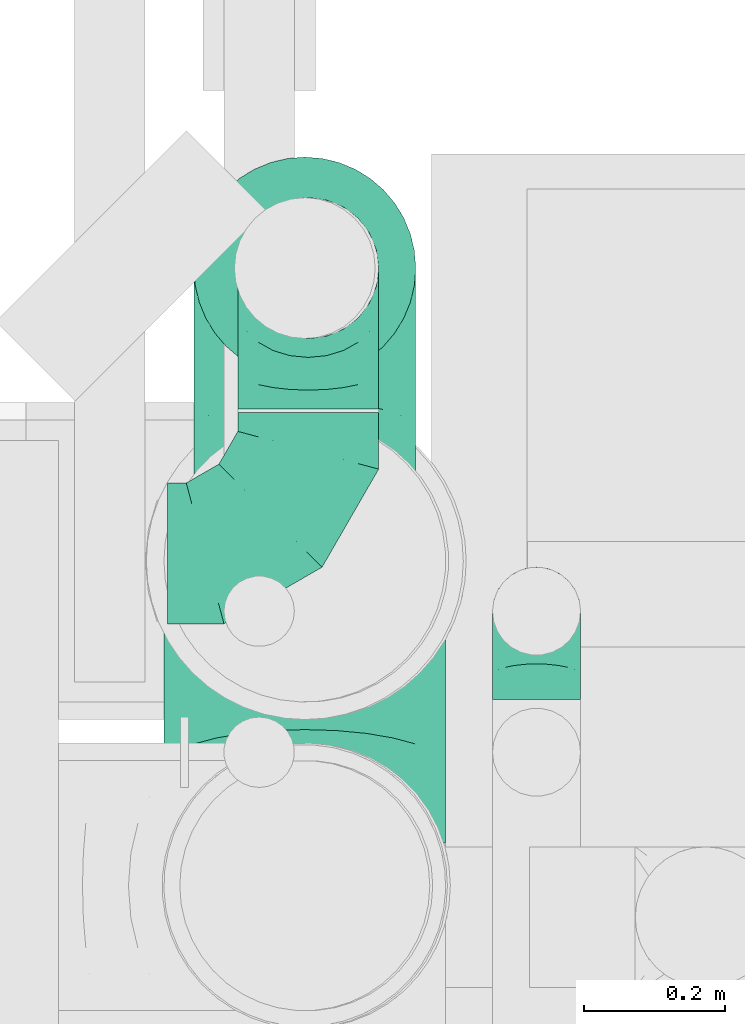
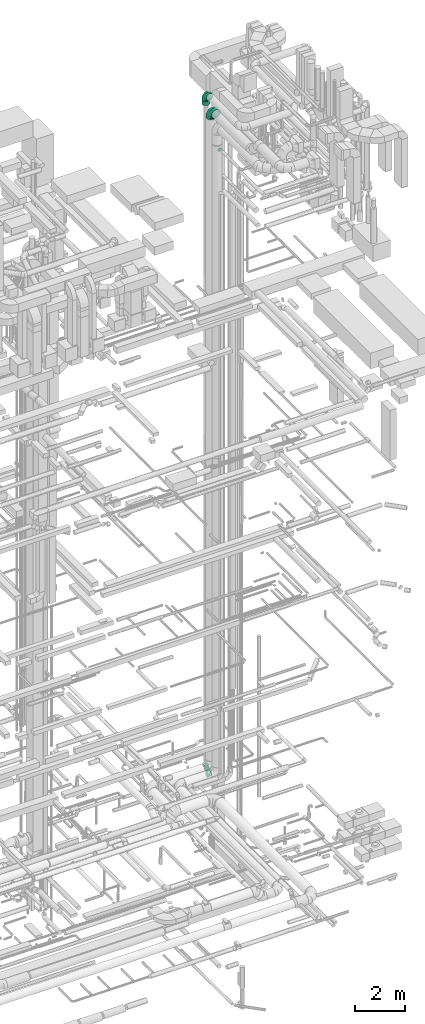
# One storey, part 270 of 337: 5 flow fittings, 1 flow segment.
"""IFC2X3 building model written with IfcOpenShell, lengths in millimetres."""

from ifc_helpers import new_model, entity, si_unit, converted_unit, derived_unit, direction, frame, origin, origin_2d_with_axis, place, context, subcontext, project, spatial, circle, extrude, faceted_brep, source, transform, mapped, material, type_object, type_shapes, element, save


model = new_model("IFC2X3")

# Units and contexts
model_context = context("Model", 3, precision=0.01, world=origin(), true_north=direction((6.12303176911189e-17, 1.0)))
body_context = subcontext(model_context, "Body", "Model", "MODEL_VIEW")
ifc_project = project(units=[si_unit("LENGTHUNIT", "METRE", prefix="MILLI"), si_unit("AREAUNIT", "SQUARE_METRE"), si_unit("VOLUMEUNIT", "CUBIC_METRE"), converted_unit("PLANEANGLEUNIT", "DEGREE", entity("IfcRatioMeasure", 0.0174532925199433), si_unit("PLANEANGLEUNIT", "RADIAN"), dimensions=[0, 0, 0, 0, 0, 0, 0]), si_unit("MASSUNIT", "GRAM", prefix="KILO"), derived_unit("MASSDENSITYUNIT", [(si_unit("MASSUNIT", "GRAM", prefix="KILO"), 1), (si_unit("LENGTHUNIT", "METRE"), -3)]), derived_unit("MOMENTOFINERTIAUNIT", [(si_unit("LENGTHUNIT", "METRE"), 4)]), si_unit("TIMEUNIT", "SECOND"), si_unit("FREQUENCYUNIT", "HERTZ"), si_unit("THERMODYNAMICTEMPERATUREUNIT", "DEGREE_CELSIUS"), derived_unit("THERMALTRANSMITTANCEUNIT", [(si_unit("MASSUNIT", "GRAM", prefix="KILO"), 1), (si_unit("THERMODYNAMICTEMPERATUREUNIT", "KELVIN"), -1), (si_unit("TIMEUNIT", "SECOND"), -3)]), derived_unit("VOLUMETRICFLOWRATEUNIT", [(si_unit("LENGTHUNIT", "METRE"), 3), (si_unit("TIMEUNIT", "SECOND"), -1)]), derived_unit("MASSFLOWRATEUNIT", [(si_unit("MASSUNIT", "GRAM", prefix="KILO"), 1), (si_unit("TIMEUNIT", "SECOND"), -1)]), derived_unit("ROTATIONALFREQUENCYUNIT", [(si_unit("TIMEUNIT", "SECOND"), -1)]), si_unit("ELECTRICCURRENTUNIT", "AMPERE"), si_unit("ELECTRICVOLTAGEUNIT", "VOLT"), si_unit("POWERUNIT", "WATT"), si_unit("FORCEUNIT", "NEWTON", prefix="KILO"), si_unit("ILLUMINANCEUNIT", "LUX"), si_unit("LUMINOUSFLUXUNIT", "LUMEN"), si_unit("LUMINOUSINTENSITYUNIT", "CANDELA"), derived_unit("USERDEFINED", [(si_unit("MASSUNIT", "GRAM", prefix="KILO"), -1), (si_unit("LENGTHUNIT", "METRE"), -2), (si_unit("TIMEUNIT", "SECOND"), 3), (si_unit("LUMINOUSFLUXUNIT", "LUMEN"), 1)]), derived_unit("LINEARVELOCITYUNIT", [(si_unit("LENGTHUNIT", "METRE"), 1), (si_unit("TIMEUNIT", "SECOND"), -1)]), si_unit("PRESSUREUNIT", "PASCAL"), derived_unit("USERDEFINED", [(si_unit("LENGTHUNIT", "METRE"), -2), (si_unit("MASSUNIT", "GRAM", prefix="KILO"), 1), (si_unit("TIMEUNIT", "SECOND"), -2)]), derived_unit("LINEARFORCEUNIT", [(si_unit("MASSUNIT", "GRAM", prefix="KILO"), 1), (si_unit("LENGTHUNIT", "METRE"), 1), (si_unit("TIMEUNIT", "SECOND"), -2), (si_unit("LENGTHUNIT", "METRE"), -1)]), derived_unit("PLANARFORCEUNIT", [(si_unit("MASSUNIT", "GRAM", prefix="KILO"), 1), (si_unit("LENGTHUNIT", "METRE"), 1), (si_unit("TIMEUNIT", "SECOND"), -2), (si_unit("LENGTHUNIT", "METRE"), -2)])], contexts=[model_context])

# Site, building, storey
site_placement = place(None, origin())
site = spatial("IfcSite", under=ifc_project, at=site_placement, CompositionType="ELEMENT")
building_placement = place(site_placement, origin())
building = spatial("IfcBuilding", under=site, at=building_placement, CompositionType="ELEMENT")
storey_placement = place(building_placement, origin())
storey = spatial("IfcBuildingStorey", under=building, at=storey_placement, CompositionType="ELEMENT", Elevation=0.0)

# Flow segment
duct_segment_type = type_object("IfcDuctSegmentType", PredefinedType="NOTDEFINED")
flow_segment_placement = place(storey_placement, frame((67399.96, 12506.71, 35005.21)))
element("IfcFlowSegment", 1, at=flow_segment_placement, inside=storey, type_object=duct_segment_type, context=body_context, shape_type="SweptSolid", body=[
    extrude(circle(Radius=157.5, at=origin_2d_with_axis()), frame((159.1, 159.1, 0.0), z_axis=(0.0, 0.0, 1.0), x_axis=(0.0, 1.0, 0.0)), (0.0, 0.0, 1.0), 199.793476749962),
])

# Flow fittings
ifc_material = material()
duct_fitting_type_1 = type_object("IfcDuctFittingType", PredefinedType="NOTDEFINED", material=ifc_material)
shared_shape_1 = source(origin(), body_context, "Body", "Brep", [
    faceted_brep([(-200.0, 0.0, -100.0), (-200.0, -25.88, -96.59), (-200.0, -50.0, -86.6), (-200.0, -70.71, -70.71), (-200.0, -86.6, -50.0), (-200.0, -96.59, -25.88), (-200.0, -100.0, 0.0), (-200.0, -96.59, 25.88), (-200.0, -86.6, 50.0), (-200.0, -70.71, 70.71), (-200.0, -50.0, 86.6), (-200.0, -25.88, 96.59), (-200.0, 0.0, 100.0), (-200.0, 25.88, 96.59), (-200.0, 50.0, 86.6), (-200.0, 70.71, 70.71), (-200.0, 86.6, 50.0), (-200.0, 96.59, 25.88), (-200.0, 100.0, 0.0), (-200.0, 96.59, -25.88), (-200.0, 86.6, -50.0), (-200.0, 70.71, -70.71), (-200.0, 50.0, -86.6), (-200.0, 25.88, -96.59), (-153.35, 25.88, 96.59), (-159.81, 50.0, 86.6), (-146.41, 0.0, 100.0), (-165.36, 70.71, 70.71), (-172.29, 96.59, 25.88), (-173.21, 100.0, 0.0), (-169.62, 86.6, 50.0), (-169.62, 86.6, -50.0), (-165.36, 70.71, -70.71), (-172.29, 96.59, -25.88), (-153.35, 25.88, -96.59), (-146.41, 0.0, -100.0), (-159.81, 50.0, -86.6), (-139.48, -25.88, -96.59), (-133.01, -50.0, -86.6), (-127.46, -70.71, -70.71), (-123.21, -86.6, -50.0), (-120.53, -96.59, -25.88), (-119.62, -100.0, 0.0), (-120.53, -96.59, 25.88), (-123.21, -86.6, 50.0), (-127.46, -70.71, 70.71), (-133.01, -50.0, 86.6), (-139.48, -25.88, 96.59), (-72.54, 72.54, 96.59), (-90.19, 90.19, 86.6), (-53.59, 53.59, 100.0), (-105.35, 105.35, 70.71), (-116.99, 116.99, 50.0), (-124.3, 124.3, 25.88), (-126.79, 126.79, 0.0), (-124.3, 124.3, -25.88), (-116.99, 116.99, -50.0), (-105.35, 105.35, -70.71), (-72.54, 72.54, -96.59), (-53.59, 53.59, -100.0), (-90.19, 90.19, -86.6), (-34.64, 34.64, -96.59), (-16.99, 16.99, -86.6), (-1.83, 1.83, -70.71), (9.81, -9.81, -50.0), (17.12, -17.12, -25.88), (19.62, -19.62, 0.0), (17.12, -17.12, 25.88), (9.81, -9.81, 50.0), (-1.83, 1.83, 70.71), (-16.99, 16.99, 86.6), (-34.64, 34.64, 96.59), (-25.88, 153.35, 96.59), (-50.0, 159.81, 86.6), (0.0, 146.41, 100.0), (-70.71, 165.36, 70.71), (-86.6, 169.62, 50.0), (-96.59, 172.29, 25.88), (-100.0, 173.21, 0.0), (-96.59, 172.29, -25.88), (-86.6, 169.62, -50.0), (-70.71, 165.36, -70.71), (-25.88, 153.35, -96.59), (0.0, 146.41, -100.0), (-50.0, 159.81, -86.6), (25.88, 139.48, -96.59), (50.0, 133.01, -86.6), (70.71, 127.46, -70.71), (86.6, 123.21, -50.0), (96.59, 120.53, -25.88), (100.0, 119.62, 0.0), (96.59, 120.53, 25.88), (86.6, 123.21, 50.0), (70.71, 127.46, 70.71), (50.0, 133.01, 86.6), (25.88, 139.48, 96.59), (-25.88, 200.0, -96.59), (-50.0, 200.0, -86.6), (-70.71, 200.0, -70.71), (-86.6, 200.0, -50.0), (-96.59, 200.0, -25.88), (-100.0, 200.0, 0.0), (-96.59, 200.0, 25.88), (-86.6, 200.0, 50.0), (-70.71, 200.0, 70.71), (-50.0, 200.0, 86.6), (-25.88, 200.0, 96.59), (0.0, 200.0, 100.0), (25.88, 200.0, 96.59), (50.0, 200.0, 86.6), (70.71, 200.0, 70.71), (86.6, 200.0, 50.0), (96.59, 200.0, 25.88), (100.0, 200.0, 0.0), (96.59, 200.0, -25.88), (86.6, 200.0, -50.0), (70.71, 200.0, -70.71), (50.0, 200.0, -86.6), (25.88, 200.0, -96.59), (0.0, 200.0, -100.0)], [[[0, 1, 2, 3, 4, 5, 6, 7, 8, 9, 10, 11, 12, 13, 14, 15, 16, 17, 18, 19, 20, 21, 22, 23]], [[24, 25, 14, 13]], [[26, 24, 13, 12]], [[14, 25, 27, 15]], [[28, 29, 18, 17]], [[30, 28, 17, 16]], [[15, 27, 30, 16]], [[20, 31, 32, 21]], [[33, 31, 20, 19]], [[18, 29, 33, 19]], [[34, 35, 0, 23]], [[36, 34, 23, 22]], [[32, 36, 22, 21]], [[1, 0, 35, 37]], [[2, 1, 37, 38]], [[38, 39, 3, 2]], [[5, 4, 40, 41]], [[6, 5, 41, 42]], [[39, 40, 4, 3]], [[6, 42, 43, 7]], [[7, 43, 44, 8]], [[8, 44, 45, 9]], [[9, 45, 46, 10]], [[10, 46, 47, 11]], [[26, 12, 11, 47]], [[48, 49, 25, 24]], [[50, 48, 24, 26]], [[27, 25, 49, 51]], [[52, 53, 28, 30]], [[51, 52, 30, 27]], [[29, 28, 53, 54]], [[55, 56, 31, 33]], [[54, 55, 33, 29]], [[32, 31, 56, 57]], [[58, 59, 35, 34]], [[60, 58, 34, 36]], [[57, 60, 36, 32]], [[37, 35, 59, 61]], [[38, 37, 61, 62]], [[39, 38, 62, 63]], [[41, 40, 64, 65]], [[42, 41, 65, 66]], [[63, 64, 40, 39]], [[43, 42, 66, 67]], [[44, 43, 67, 68]], [[68, 69, 45, 44]], [[46, 45, 69, 70]], [[47, 46, 70, 71]], [[26, 47, 71, 50]], [[72, 73, 49, 48]], [[74, 72, 48, 50]], [[51, 49, 73, 75]], [[76, 77, 53, 52]], [[75, 76, 52, 51]], [[54, 53, 77, 78]], [[79, 80, 56, 55]], [[78, 79, 55, 54]], [[57, 56, 80, 81]], [[82, 83, 59, 58]], [[84, 82, 58, 60]], [[81, 84, 60, 57]], [[61, 59, 83, 85]], [[62, 61, 85, 86]], [[63, 62, 86, 87]], [[65, 64, 88, 89]], [[66, 65, 89, 90]], [[87, 88, 64, 63]], [[67, 66, 90, 91]], [[68, 67, 91, 92]], [[92, 93, 69, 68]], [[70, 69, 93, 94]], [[71, 70, 94, 95]], [[50, 71, 95, 74]], [[96, 97, 98, 99, 100, 101, 102, 103, 104, 105, 106, 107, 108, 109, 110, 111, 112, 113, 114, 115, 116, 117, 118, 119]], [[72, 74, 107, 106]], [[73, 72, 106, 105]], [[75, 73, 105, 104]], [[102, 101, 78, 77]], [[103, 102, 77, 76]], [[75, 104, 103, 76]], [[78, 101, 100, 79]], [[79, 100, 99, 80]], [[80, 99, 98, 81]], [[84, 97, 96, 82]], [[82, 96, 119, 83]], [[84, 81, 98, 97]], [[118, 117, 86, 85]], [[119, 118, 85, 83]], [[116, 87, 86, 117]], [[88, 115, 114, 89]], [[89, 114, 113, 90]], [[115, 88, 87, 116]], [[91, 90, 113, 112]], [[92, 91, 112, 111]], [[111, 110, 93, 92]], [[95, 94, 109, 108]], [[74, 95, 108, 107]], [[110, 109, 94, 93]]]),
])
type_shapes(duct_fitting_type_1, [shared_shape_1])
flow_fitting_1_placement = place(storey_placement, frame((67563.97, 12260.8, 2700.0)))
element("IfcFlowFitting", 2, at=flow_fitting_1_placement, inside=storey, type_object=duct_fitting_type_1, material=ifc_material, context=body_context, shape_type="MappedRepresentation", body=[
    mapped(shared_shape_1, transform((0.0, 0.0, 0.0), scale=1.0)),
])
flow_fitting_2_placement = place(storey_placement, frame((67563.97, 12665.8, 2700.0), z_axis=(0.999999988322799, 0.0, 0.000152821469941367), x_axis=(0.0, 1.0, 0.0)))
element("IfcFlowFitting", 3, at=flow_fitting_2_placement, inside=storey, type_object=duct_fitting_type_1, material=ifc_material, context=body_context, shape_type="MappedRepresentation", body=[
    mapped(shared_shape_1, transform((0.0, 0.0, 0.0), scale=1.0)),
])
duct_fitting_type_2 = type_object("IfcDuctFittingType", PredefinedType="NOTDEFINED", material=ifc_material)
shared_shape_2 = source(origin(), body_context, "Body", "Brep", [
    faceted_brep([(-125.0, 0.0, -62.5), (-125.0, -16.18, -60.37), (-125.0, -31.25, -54.13), (-125.0, -44.19, -44.19), (-125.0, -54.13, -31.25), (-125.0, -60.37, -16.18), (-125.0, -62.5, 0.0), (-125.0, -60.37, 16.18), (-125.0, -54.13, 31.25), (-125.0, -44.19, 44.19), (-125.0, -31.25, 54.13), (-125.0, -16.18, 60.37), (-125.0, 0.0, 62.5), (-125.0, 16.18, 60.37), (-125.0, 31.25, 54.13), (-125.0, 44.19, 44.19), (-125.0, 54.13, 31.25), (-125.0, 60.37, 16.18), (-125.0, 62.5, 0.0), (-125.0, 60.37, -16.18), (-125.0, 54.13, -31.25), (-125.0, 44.19, -44.19), (-125.0, 31.25, -54.13), (-125.0, 16.18, -60.37), (-95.84, 16.18, 60.37), (-99.88, 31.25, 54.13), (-91.51, 0.0, 62.5), (-103.35, 44.19, 44.19), (-107.68, 60.37, 16.18), (-108.25, 62.5, 0.0), (-106.01, 54.13, 31.25), (-106.01, 54.13, -31.25), (-103.35, 44.19, -44.19), (-107.68, 60.37, -16.18), (-95.84, 16.18, -60.37), (-91.51, 0.0, -62.5), (-99.88, 31.25, -54.13), (-87.17, -16.18, -60.37), (-83.13, -31.25, -54.13), (-79.66, -44.19, -44.19), (-77.0, -54.13, -31.25), (-75.33, -60.37, -16.18), (-74.76, -62.5, 0.0), (-75.33, -60.37, 16.18), (-77.0, -54.13, 31.25), (-79.66, -44.19, 44.19), (-83.13, -31.25, 54.13), (-87.17, -16.18, 60.37), (-45.34, 45.34, 60.37), (-56.37, 56.37, 54.13), (-33.49, 33.49, 62.5), (-65.85, 65.85, 44.19), (-73.12, 73.12, 31.25), (-77.69, 77.69, 16.18), (-79.25, 79.25, 0.0), (-77.69, 77.69, -16.18), (-73.12, 73.12, -31.25), (-65.85, 65.85, -44.19), (-45.34, 45.34, -60.37), (-33.49, 33.49, -62.5), (-56.37, 56.37, -54.13), (-21.65, 21.65, -60.37), (-10.62, 10.62, -54.13), (-1.14, 1.14, -44.19), (6.13, -6.13, -31.25), (10.7, -10.7, -16.18), (12.26, -12.26, 0.0), (10.7, -10.7, 16.18), (6.13, -6.13, 31.25), (-1.14, 1.14, 44.19), (-10.62, 10.62, 54.13), (-21.65, 21.65, 60.37), (-16.18, 95.84, 60.37), (-31.25, 99.88, 54.13), (0.0, 91.51, 62.5), (-44.19, 103.35, 44.19), (-54.13, 106.01, 31.25), (-60.37, 107.68, 16.18), (-62.5, 108.25, 0.0), (-60.37, 107.68, -16.18), (-54.13, 106.01, -31.25), (-44.19, 103.35, -44.19), (-16.18, 95.84, -60.37), (0.0, 91.51, -62.5), (-31.25, 99.88, -54.13), (16.18, 87.17, -60.37), (31.25, 83.13, -54.13), (44.19, 79.66, -44.19), (54.13, 77.0, -31.25), (60.37, 75.33, -16.18), (62.5, 74.76, 0.0), (60.37, 75.33, 16.18), (54.13, 77.0, 31.25), (44.19, 79.66, 44.19), (31.25, 83.13, 54.13), (16.18, 87.17, 60.37), (-16.18, 125.0, -60.37), (-31.25, 125.0, -54.13), (-44.19, 125.0, -44.19), (-54.13, 125.0, -31.25), (-60.37, 125.0, -16.18), (-62.5, 125.0, 0.0), (-60.37, 125.0, 16.18), (-54.13, 125.0, 31.25), (-44.19, 125.0, 44.19), (-31.25, 125.0, 54.13), (-16.18, 125.0, 60.37), (0.0, 125.0, 62.5), (16.18, 125.0, 60.37), (31.25, 125.0, 54.13), (44.19, 125.0, 44.19), (54.13, 125.0, 31.25), (60.37, 125.0, 16.18), (62.5, 125.0, 0.0), (60.37, 125.0, -16.18), (54.13, 125.0, -31.25), (44.19, 125.0, -44.19), (31.25, 125.0, -54.13), (16.18, 125.0, -60.37), (0.0, 125.0, -62.5)], [[[0, 1, 2, 3, 4, 5, 6, 7, 8, 9, 10, 11, 12, 13, 14, 15, 16, 17, 18, 19, 20, 21, 22, 23]], [[24, 25, 14, 13]], [[26, 24, 13, 12]], [[14, 25, 27, 15]], [[28, 29, 18, 17]], [[30, 28, 17, 16]], [[15, 27, 30, 16]], [[20, 31, 32, 21]], [[33, 31, 20, 19]], [[18, 29, 33, 19]], [[34, 35, 0, 23]], [[36, 34, 23, 22]], [[21, 32, 36, 22]], [[1, 0, 35, 37]], [[2, 1, 37, 38]], [[38, 39, 3, 2]], [[5, 4, 40, 41]], [[6, 5, 41, 42]], [[39, 40, 4, 3]], [[6, 42, 43, 7]], [[7, 43, 44, 8]], [[45, 9, 8, 44]], [[9, 45, 46, 10]], [[10, 46, 47, 11]], [[26, 12, 11, 47]], [[48, 49, 25, 24]], [[50, 48, 24, 26]], [[27, 25, 49, 51]], [[52, 53, 28, 30]], [[51, 52, 30, 27]], [[29, 28, 53, 54]], [[55, 56, 31, 33]], [[54, 55, 33, 29]], [[57, 32, 31, 56]], [[58, 59, 35, 34]], [[60, 58, 34, 36]], [[57, 60, 36, 32]], [[37, 35, 59, 61]], [[38, 37, 61, 62]], [[39, 38, 62, 63]], [[41, 40, 64, 65]], [[42, 41, 65, 66]], [[63, 64, 40, 39]], [[43, 42, 66, 67]], [[44, 43, 67, 68]], [[68, 69, 45, 44]], [[46, 45, 69, 70]], [[47, 46, 70, 71]], [[26, 47, 71, 50]], [[72, 73, 49, 48]], [[74, 72, 48, 50]], [[51, 49, 73, 75]], [[76, 77, 53, 52]], [[75, 76, 52, 51]], [[54, 53, 77, 78]], [[79, 80, 56, 55]], [[78, 79, 55, 54]], [[81, 57, 56, 80]], [[82, 83, 59, 58]], [[84, 82, 58, 60]], [[81, 84, 60, 57]], [[61, 59, 83, 85]], [[62, 61, 85, 86]], [[63, 62, 86, 87]], [[65, 64, 88, 89]], [[66, 65, 89, 90]], [[87, 88, 64, 63]], [[67, 66, 90, 91]], [[68, 67, 91, 92]], [[92, 93, 69, 68]], [[70, 69, 93, 94]], [[71, 70, 94, 95]], [[50, 71, 95, 74]], [[96, 97, 98, 99, 100, 101, 102, 103, 104, 105, 106, 107, 108, 109, 110, 111, 112, 113, 114, 115, 116, 117, 118, 119]], [[72, 74, 107, 106]], [[73, 72, 106, 105]], [[75, 73, 105, 104]], [[77, 76, 103, 102]], [[78, 77, 102, 101]], [[75, 104, 103, 76]], [[78, 101, 100, 79]], [[79, 100, 99, 80]], [[80, 99, 98, 81]], [[96, 119, 83, 82]], [[97, 96, 82, 84]], [[84, 81, 98, 97]], [[83, 119, 118, 85]], [[85, 118, 117, 86]], [[116, 87, 86, 117]], [[88, 115, 114, 89]], [[89, 114, 113, 90]], [[115, 88, 87, 116]], [[91, 90, 113, 112]], [[92, 91, 112, 111]], [[111, 110, 93, 92]], [[95, 94, 109, 108]], [[74, 95, 108, 107]], [[110, 109, 94, 93]]]),
])
type_shapes(duct_fitting_type_2, [shared_shape_2])
flow_fitting_3_placement = place(storey_placement, frame((67888.0, 12178.74, 33015.0), z_axis=(-1.0, 0.0, 0.0), x_axis=(0.0, 1.0, 0.0)))
element("IfcFlowFitting", 4, at=flow_fitting_3_placement, inside=storey, type_object=duct_fitting_type_2, material=ifc_material, context=body_context, shape_type="MappedRepresentation", body=[
    mapped(shared_shape_2, transform((0.0, 0.0, 0.0), scale=1.0)),
])
duct_fitting_type_3 = type_object("IfcDuctFittingType", PredefinedType="NOTDEFINED", material=ifc_material)
shared_shape_3 = source(origin(), body_context, "Body", "Brep", [
    faceted_brep([(-400.0, 0.0, -200.0), (-400.0, -44.5, -194.99), (-400.0, -86.78, -180.19), (-400.0, -124.7, -156.37), (-400.0, -156.37, -124.7), (-400.0, -180.19, -86.78), (-400.0, -194.99, -44.5), (-400.0, -200.0, 0.0), (-400.0, -194.99, 44.5), (-400.0, -180.19, 86.78), (-400.0, -156.37, 124.7), (-400.0, -124.7, 156.37), (-400.0, -86.78, 180.19), (-400.0, -44.5, 194.99), (-400.0, 0.0, 200.0), (-400.0, 44.5, 194.99), (-400.0, 86.78, 180.19), (-400.0, 124.7, 156.37), (-400.0, 156.37, 124.7), (-400.0, 180.19, 86.78), (-400.0, 194.99, 44.5), (-400.0, 200.0, 0.0), (-400.0, 194.99, -44.5), (-400.0, 180.19, -86.78), (-400.0, 156.37, -124.7), (-400.0, 124.7, -156.37), (-400.0, 86.78, -180.19), (-400.0, 44.5, -194.99), (-292.82, 0.0, 200.0), (-304.75, 44.5, 194.99), (-316.07, 86.78, 180.19), (-326.23, 124.7, 156.37), (-334.72, 156.37, 124.7), (-341.1, 180.19, 86.78), (-345.07, 194.99, 44.5), (-346.41, 200.0, 0.0), (-345.07, 194.99, -44.5), (-341.1, 180.19, -86.78), (-334.72, 156.37, -124.7), (-326.23, 124.7, -156.37), (-316.07, 86.78, -180.19), (-304.75, 44.5, -194.99), (-292.82, 0.0, -200.0), (-280.9, -44.5, -194.99), (-269.57, -86.78, -180.19), (-259.41, -124.7, -156.37), (-250.92, -156.37, -124.7), (-244.54, -180.19, -86.78), (-240.57, -194.99, -44.5), (-239.23, -200.0, 0.0), (-240.57, -194.99, 44.5), (-244.54, -180.19, 86.78), (-250.92, -156.37, 124.7), (-259.41, -124.7, 156.37), (-269.57, -86.78, 180.19), (-280.9, -44.5, 194.99), (-107.18, 107.18, 200.0), (-139.76, 139.76, 194.99), (-170.7, 170.7, 180.19), (-198.46, 198.46, 156.37), (-221.65, 221.65, 124.7), (-239.09, 239.09, 86.78), (-249.92, 249.92, 44.5), (-253.59, 253.59, 0.0), (-249.92, 249.92, -44.5), (-239.09, 239.09, -86.78), (-221.65, 221.65, -124.7), (-198.46, 198.46, -156.37), (-170.7, 170.7, -180.19), (-139.76, 139.76, -194.99), (-107.18, 107.18, -200.0), (-74.6, 74.6, -194.99), (-43.65, 43.65, -180.19), (-15.89, 15.89, -156.37), (7.29, -7.29, -124.7), (24.73, -24.73, -86.78), (35.56, -35.56, -44.5), (39.23, -39.23, 0.0), (35.56, -35.56, 44.5), (24.73, -24.73, 86.78), (7.29, -7.29, 124.7), (-15.89, 15.89, 156.37), (-43.65, 43.65, 180.19), (-74.6, 74.6, 194.99), (0.0, 292.82, 200.0), (-44.5, 304.75, 194.99), (-86.78, 316.07, 180.19), (-124.7, 326.23, 156.37), (-156.37, 334.72, 124.7), (-180.19, 341.1, 86.78), (-194.99, 345.07, 44.5), (-200.0, 346.41, 0.0), (-194.99, 345.07, -44.5), (-180.19, 341.1, -86.78), (-156.37, 334.72, -124.7), (-124.7, 326.23, -156.37), (-86.78, 316.07, -180.19), (-44.5, 304.75, -194.99), (0.0, 292.82, -200.0), (44.5, 280.9, -194.99), (86.78, 269.57, -180.19), (124.7, 259.41, -156.37), (156.37, 250.92, -124.7), (180.19, 244.54, -86.78), (194.99, 240.57, -44.5), (200.0, 239.23, 0.0), (194.99, 240.57, 44.5), (180.19, 244.54, 86.78), (156.37, 250.92, 124.7), (124.7, 259.41, 156.37), (86.78, 269.57, 180.19), (44.5, 280.9, 194.99), (-44.5, 400.0, -194.99), (-86.78, 400.0, -180.19), (-124.7, 400.0, -156.37), (-156.37, 400.0, -124.7), (-180.19, 400.0, -86.78), (-194.99, 400.0, -44.5), (-200.0, 400.0, 0.0), (-194.99, 400.0, 44.5), (-180.19, 400.0, 86.78), (-156.37, 400.0, 124.7), (-124.7, 400.0, 156.37), (-86.78, 400.0, 180.19), (-44.5, 400.0, 194.99), (0.0, 400.0, 200.0), (44.5, 400.0, 194.99), (86.78, 400.0, 180.19), (124.7, 400.0, 156.37), (156.37, 400.0, 124.7), (180.19, 400.0, 86.78), (194.99, 400.0, 44.5), (200.0, 400.0, 0.0), (194.99, 400.0, -44.5), (180.19, 400.0, -86.78), (156.37, 400.0, -124.7), (124.7, 400.0, -156.37), (86.78, 400.0, -180.19), (44.5, 400.0, -194.99), (0.0, 400.0, -200.0)], [[[0, 1, 2, 3, 4, 5, 6, 7, 8, 9, 10, 11, 12, 13, 14, 15, 16, 17, 18, 19, 20, 21, 22, 23, 24, 25, 26, 27]], [[28, 29, 15, 14]], [[30, 31, 17, 16]], [[29, 30, 16, 15]], [[31, 32, 18, 17]], [[32, 33, 19, 18]], [[34, 35, 21, 20]], [[33, 34, 20, 19]], [[35, 36, 22, 21]], [[37, 38, 24, 23]], [[36, 37, 23, 22]], [[38, 39, 25, 24]], [[39, 40, 26, 25]], [[41, 42, 0, 27]], [[40, 41, 27, 26]], [[1, 0, 42, 43]], [[43, 44, 2, 1]], [[45, 3, 2, 44]], [[45, 46, 4, 3]], [[5, 4, 46, 47]], [[47, 48, 6, 5]], [[49, 7, 6, 48]], [[7, 49, 50, 8]], [[8, 50, 51, 9]], [[9, 51, 52, 10]], [[52, 53, 11, 10]], [[11, 53, 54, 12]], [[12, 54, 55, 13]], [[13, 55, 28, 14]], [[56, 57, 29, 28]], [[58, 59, 31, 30]], [[57, 58, 30, 29]], [[59, 60, 32, 31]], [[60, 61, 33, 32]], [[62, 63, 35, 34]], [[61, 62, 34, 33]], [[63, 64, 36, 35]], [[65, 66, 38, 37]], [[64, 65, 37, 36]], [[66, 67, 39, 38]], [[67, 68, 40, 39]], [[69, 70, 42, 41]], [[68, 69, 41, 40]], [[43, 42, 70, 71]], [[71, 72, 44, 43]], [[73, 45, 44, 72]], [[73, 74, 46, 45]], [[47, 46, 74, 75]], [[75, 76, 48, 47]], [[77, 49, 48, 76]], [[50, 49, 77, 78]], [[51, 50, 78, 79]], [[52, 51, 79, 80]], [[80, 81, 53, 52]], [[54, 53, 81, 82]], [[55, 54, 82, 83]], [[28, 55, 83, 56]], [[84, 85, 57, 56]], [[86, 87, 59, 58]], [[85, 86, 58, 57]], [[87, 88, 60, 59]], [[88, 89, 61, 60]], [[90, 91, 63, 62]], [[89, 90, 62, 61]], [[91, 92, 64, 63]], [[93, 94, 66, 65]], [[92, 93, 65, 64]], [[94, 95, 67, 66]], [[95, 96, 68, 67]], [[97, 98, 70, 69]], [[96, 97, 69, 68]], [[71, 70, 98, 99]], [[99, 100, 72, 71]], [[101, 73, 72, 100]], [[101, 102, 74, 73]], [[75, 74, 102, 103]], [[103, 104, 76, 75]], [[105, 77, 76, 104]], [[78, 77, 105, 106]], [[79, 78, 106, 107]], [[80, 79, 107, 108]], [[108, 109, 81, 80]], [[82, 81, 109, 110]], [[83, 82, 110, 111]], [[56, 83, 111, 84]], [[112, 113, 114, 115, 116, 117, 118, 119, 120, 121, 122, 123, 124, 125, 126, 127, 128, 129, 130, 131, 132, 133, 134, 135, 136, 137, 138, 139]], [[85, 84, 125, 124]], [[86, 85, 124, 123]], [[87, 86, 123, 122]], [[122, 121, 88, 87]], [[89, 88, 121, 120]], [[90, 89, 120, 119]], [[91, 90, 119, 118]], [[91, 118, 117, 92]], [[92, 117, 116, 93]], [[93, 116, 115, 94]], [[115, 114, 95, 94]], [[95, 114, 113, 96]], [[96, 113, 112, 97]], [[97, 112, 139, 98]], [[98, 139, 138, 99]], [[99, 138, 137, 100]], [[100, 137, 136, 101]], [[136, 135, 102, 101]], [[102, 135, 134, 103]], [[103, 134, 133, 104]], [[104, 133, 132, 105]], [[106, 105, 132, 131]], [[107, 106, 131, 130]], [[108, 107, 130, 129]], [[129, 128, 109, 108]], [[110, 109, 128, 127]], [[111, 110, 127, 126]], [[84, 111, 126, 125]]]),
])
type_shapes(duct_fitting_type_3, [shared_shape_3])
flow_fitting_4_placement = place(storey_placement, frame((67559.05, 12249.91, 35000.0), z_axis=(0.999999991316283, 0.0, 0.000131785563679762), x_axis=(-0.000131785563679762, 0.0, 0.999999991316283)))
element("IfcFlowFitting", 5, at=flow_fitting_4_placement, inside=storey, type_object=duct_fitting_type_3, material=ifc_material, context=body_context, shape_type="MappedRepresentation", body=[
    mapped(shared_shape_3, transform((0.0, 0.0, 0.0), scale=1.0)),
])
duct_fitting_type_4 = type_object("IfcDuctFittingType", PredefinedType="NOTDEFINED", material=ifc_material)
shared_shape_4 = source(origin(), body_context, "Body", "Brep", [
    faceted_brep([(-315.0, 0.0, -157.5), (-315.0, -40.76, -152.13), (-315.0, -78.75, -136.4), (-315.0, -111.37, -111.37), (-315.0, -136.4, -78.75), (-315.0, -152.13, -40.76), (-315.0, -157.5, 0.0), (-315.0, -152.13, 40.76), (-315.0, -136.4, 78.75), (-315.0, -111.37, 111.37), (-315.0, -78.75, 136.4), (-315.0, -40.76, 152.13), (-315.0, 0.0, 157.5), (-315.0, 40.76, 152.13), (-315.0, 78.75, 136.4), (-315.0, 111.37, 111.37), (-315.0, 136.4, 78.75), (-315.0, 152.13, 40.76), (-315.0, 157.5, 0.0), (-315.0, 152.13, -40.76), (-315.0, 136.4, -78.75), (-315.0, 111.37, -111.37), (-315.0, 78.75, -136.4), (-315.0, 40.76, -152.13), (-241.52, 40.76, 152.13), (-251.7, 78.75, 136.4), (-230.6, 0.0, 157.5), (-260.44, 111.37, 111.37), (-271.36, 152.13, 40.76), (-272.8, 157.5, 0.0), (-267.14, 136.4, 78.75), (-267.14, 136.4, -78.75), (-260.44, 111.37, -111.37), (-271.36, 152.13, -40.76), (-241.52, 40.76, -152.13), (-230.6, 0.0, -157.5), (-251.7, 78.75, -136.4), (-219.67, -40.76, -152.13), (-209.5, -78.75, -136.4), (-200.75, -111.37, -111.37), (-194.05, -136.4, -78.75), (-189.83, -152.13, -40.76), (-188.39, -157.5, 0.0), (-189.83, -152.13, 40.76), (-194.05, -136.4, 78.75), (-200.75, -111.37, 111.37), (-209.5, -78.75, 136.4), (-219.67, -40.76, 152.13), (-114.25, 114.25, 152.13), (-142.05, 142.05, 136.4), (-84.4, 84.4, 157.5), (-165.93, 165.93, 111.37), (-184.25, 184.25, 78.75), (-195.77, 195.77, 40.76), (-199.7, 199.7, 0.0), (-195.77, 195.77, -40.76), (-184.25, 184.25, -78.75), (-165.93, 165.93, -111.37), (-114.25, 114.25, -152.13), (-84.4, 84.4, -157.5), (-142.05, 142.05, -136.4), (-54.56, 54.56, -152.13), (-26.75, 26.75, -136.4), (-2.88, 2.88, -111.37), (15.45, -15.45, -78.75), (26.97, -26.97, -40.76), (30.89, -30.89, 0.0), (26.97, -26.97, 40.76), (15.45, -15.45, 78.75), (-2.88, 2.88, 111.37), (-26.75, 26.75, 136.4), (-54.56, 54.56, 152.13), (-40.76, 241.52, 152.13), (-78.75, 251.7, 136.4), (0.0, 230.6, 157.5), (-111.37, 260.44, 111.37), (-136.4, 267.14, 78.75), (-152.13, 271.36, 40.76), (-157.5, 272.8, 0.0), (-152.13, 271.36, -40.76), (-136.4, 267.14, -78.75), (-111.37, 260.44, -111.37), (-40.76, 241.52, -152.13), (0.0, 230.6, -157.5), (-78.75, 251.7, -136.4), (40.76, 219.67, -152.13), (78.75, 209.5, -136.4), (111.37, 200.75, -111.37), (136.4, 194.05, -78.75), (152.13, 189.83, -40.76), (157.5, 188.39, 0.0), (152.13, 189.83, 40.76), (136.4, 194.05, 78.75), (111.37, 200.75, 111.37), (78.75, 209.5, 136.4), (40.76, 219.67, 152.13), (-40.76, 315.0, -152.13), (-78.75, 315.0, -136.4), (-111.37, 315.0, -111.37), (-136.4, 315.0, -78.75), (-152.13, 315.0, -40.76), (-157.5, 315.0, 0.0), (-152.13, 315.0, 40.76), (-136.4, 315.0, 78.75), (-111.37, 315.0, 111.37), (-78.75, 315.0, 136.4), (-40.76, 315.0, 152.13), (0.0, 315.0, 157.5), (40.76, 315.0, 152.13), (78.75, 315.0, 136.4), (111.37, 315.0, 111.37), (136.4, 315.0, 78.75), (152.13, 315.0, 40.76), (157.5, 315.0, 0.0), (152.13, 315.0, -40.76), (136.4, 315.0, -78.75), (111.37, 315.0, -111.37), (78.75, 315.0, -136.4), (40.76, 315.0, -152.13), (0.0, 315.0, -157.5)], [[[0, 1, 2, 3, 4, 5, 6, 7, 8, 9, 10, 11, 12, 13, 14, 15, 16, 17, 18, 19, 20, 21, 22, 23]], [[24, 25, 14, 13]], [[26, 24, 13, 12]], [[14, 25, 27, 15]], [[28, 29, 18, 17]], [[30, 28, 17, 16]], [[15, 27, 30, 16]], [[20, 31, 32, 21]], [[33, 31, 20, 19]], [[18, 29, 33, 19]], [[34, 35, 0, 23]], [[36, 34, 23, 22]], [[32, 36, 22, 21]], [[1, 0, 35, 37]], [[2, 1, 37, 38]], [[38, 39, 3, 2]], [[5, 4, 40, 41]], [[6, 5, 41, 42]], [[39, 40, 4, 3]], [[6, 42, 43, 7]], [[7, 43, 44, 8]], [[8, 44, 45, 9]], [[9, 45, 46, 10]], [[10, 46, 47, 11]], [[26, 12, 11, 47]], [[48, 49, 25, 24]], [[50, 48, 24, 26]], [[27, 25, 49, 51]], [[52, 53, 28, 30]], [[51, 52, 30, 27]], [[29, 28, 53, 54]], [[55, 56, 31, 33]], [[54, 55, 33, 29]], [[32, 31, 56, 57]], [[58, 59, 35, 34]], [[60, 58, 34, 36]], [[57, 60, 36, 32]], [[37, 35, 59, 61]], [[38, 37, 61, 62]], [[39, 38, 62, 63]], [[41, 40, 64, 65]], [[42, 41, 65, 66]], [[63, 64, 40, 39]], [[43, 42, 66, 67]], [[44, 43, 67, 68]], [[68, 69, 45, 44]], [[46, 45, 69, 70]], [[47, 46, 70, 71]], [[26, 47, 71, 50]], [[72, 73, 49, 48]], [[74, 72, 48, 50]], [[51, 49, 73, 75]], [[76, 77, 53, 52]], [[75, 76, 52, 51]], [[54, 53, 77, 78]], [[79, 80, 56, 55]], [[78, 79, 55, 54]], [[57, 56, 80, 81]], [[82, 83, 59, 58]], [[84, 82, 58, 60]], [[81, 84, 60, 57]], [[61, 59, 83, 85]], [[62, 61, 85, 86]], [[63, 62, 86, 87]], [[65, 64, 88, 89]], [[66, 65, 89, 90]], [[87, 88, 64, 63]], [[67, 66, 90, 91]], [[68, 67, 91, 92]], [[92, 93, 69, 68]], [[70, 69, 93, 94]], [[71, 70, 94, 95]], [[50, 71, 95, 74]], [[96, 97, 98, 99, 100, 101, 102, 103, 104, 105, 106, 107, 108, 109, 110, 111, 112, 113, 114, 115, 116, 117, 118, 119]], [[106, 105, 73, 72]], [[107, 106, 72, 74]], [[75, 73, 105, 104]], [[77, 76, 103, 102]], [[78, 77, 102, 101]], [[104, 103, 76, 75]], [[78, 101, 100, 79]], [[79, 100, 99, 80]], [[98, 81, 80, 99]], [[84, 97, 96, 82]], [[82, 96, 119, 83]], [[97, 84, 81, 98]], [[83, 119, 118, 85]], [[85, 118, 117, 86]], [[116, 87, 86, 117]], [[88, 115, 114, 89]], [[89, 114, 113, 90]], [[115, 88, 87, 116]], [[91, 90, 113, 112]], [[92, 91, 112, 111]], [[111, 110, 93, 92]], [[95, 94, 109, 108]], [[74, 95, 108, 107]], [[110, 109, 94, 93]]]),
])
type_shapes(duct_fitting_type_4, [shared_shape_4])
flow_fitting_5_placement = place(storey_placement, frame((67559.05, 12665.8, 35520.0), z_axis=(1.0, 0.0, 0.0), x_axis=(0.0, 0.0, 1.0)))
element("IfcFlowFitting", 6, at=flow_fitting_5_placement, inside=storey, type_object=duct_fitting_type_4, material=ifc_material, context=body_context, shape_type="MappedRepresentation", body=[
    mapped(shared_shape_4, transform((0.0, 0.0, 0.0), scale=1.0)),
])

save(model, "model.ifc")
